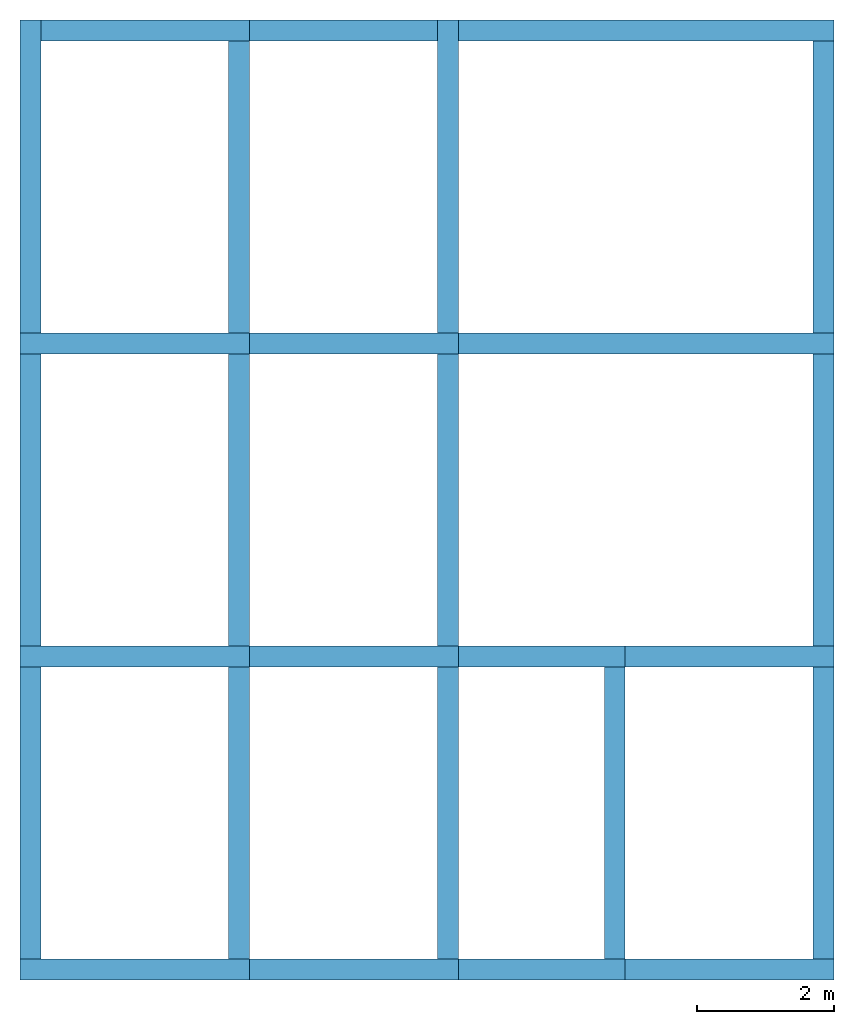
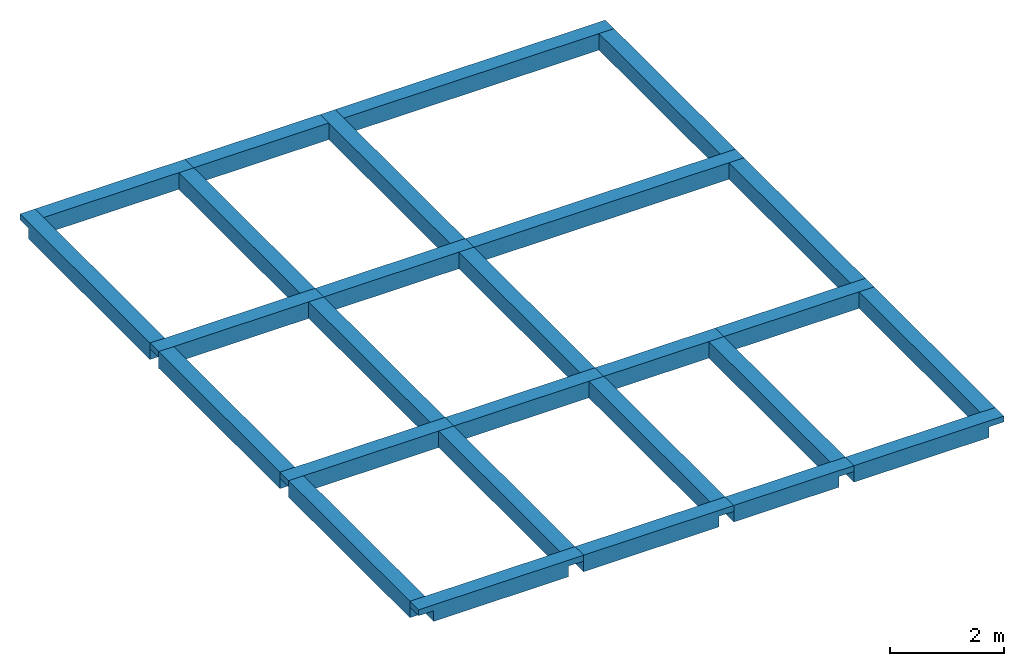
# One storey: 27 beams.
"""IFC2X3 building model written with IfcOpenShell, lengths in feet."""

from ifc_helpers import new_model, entity, si_unit, converted_unit, derived_unit, direction, frame, frame_2d, origin, place, context, subcontext, project, spatial, rectangle, extrude, faceted_brep, material, type_object, element, save


model = new_model("IFC2X3")

# Units and contexts
model_context = context("Model", 3, precision=0.0001, world=origin(), true_north=direction((6.123031769111886e-17, 1.0)))
body_context = subcontext(model_context, "Body", "Model", "MODEL_VIEW")
ifc_project = project(units=[converted_unit("LENGTHUNIT", "FOOT", entity("IfcLengthMeasure", 0.3048), si_unit("LENGTHUNIT", "METRE"), dimensions=[1, 0, 0, 0, 0, 0, 0]), converted_unit("AREAUNIT", "SQUARE FOOT", entity("IfcAreaMeasure", 0.09290304), si_unit("AREAUNIT", "SQUARE_METRE"), dimensions=[2, 0, 0, 0, 0, 0, 0]), converted_unit("VOLUMEUNIT", "CUBIC FOOT", entity("IfcVolumeMeasure", 0.028316846592000004), si_unit("VOLUMEUNIT", "CUBIC_METRE"), dimensions=[3, 0, 0, 0, 0, 0, 0]), converted_unit("PLANEANGLEUNIT", "DEGREE", entity("IfcPlaneAngleMeasure", 0.017453292519943278), si_unit("PLANEANGLEUNIT", "RADIAN"), dimensions=[0, 0, 0, 0, 0, 0, 0]), si_unit("MASSUNIT", "GRAM", prefix="KILO"), derived_unit("MASSDENSITYUNIT", [(si_unit("MASSUNIT", "GRAM", prefix="KILO"), 1), (si_unit("LENGTHUNIT", "METRE"), -3)]), derived_unit("IONCONCENTRATIONUNIT", [(si_unit("MASSUNIT", "GRAM", prefix="KILO"), 1), (si_unit("LENGTHUNIT", "METRE"), -3)]), derived_unit("MOMENTOFINERTIAUNIT", [(si_unit("LENGTHUNIT", "METRE"), 4)]), si_unit("TIMEUNIT", "SECOND"), si_unit("FREQUENCYUNIT", "HERTZ"), si_unit("THERMODYNAMICTEMPERATUREUNIT", "DEGREE_CELSIUS"), derived_unit("THERMALTRANSMITTANCEUNIT", [(si_unit("MASSUNIT", "GRAM", prefix="KILO"), 1), (si_unit("THERMODYNAMICTEMPERATUREUNIT", "KELVIN"), -1), (si_unit("TIMEUNIT", "SECOND"), -3)]), derived_unit("THERMALCONDUCTANCEUNIT", [(si_unit("MASSUNIT", "GRAM", prefix="KILO"), 1), (si_unit("THERMODYNAMICTEMPERATUREUNIT", "KELVIN"), -1), (si_unit("TIMEUNIT", "SECOND"), -3), (si_unit("LENGTHUNIT", "METRE"), 1)]), derived_unit("VOLUMETRICFLOWRATEUNIT", [(si_unit("LENGTHUNIT", "METRE"), 3), (si_unit("TIMEUNIT", "SECOND"), -1)]), derived_unit("MASSFLOWRATEUNIT", [(si_unit("MASSUNIT", "GRAM", prefix="KILO"), 1), (si_unit("TIMEUNIT", "SECOND"), -1)]), derived_unit("ROTATIONALFREQUENCYUNIT", [(si_unit("TIMEUNIT", "SECOND"), -1)]), si_unit("ELECTRICCURRENTUNIT", "AMPERE"), si_unit("ELECTRICVOLTAGEUNIT", "VOLT"), si_unit("POWERUNIT", "WATT"), converted_unit("FORCEUNIT", "KIP", entity("IfcForceMeasure", 2.088543423315013e-05), si_unit("FORCEUNIT", "NEWTON"), dimensions=[1, 1, -2, 0, 0, 0, 0]), si_unit("ILLUMINANCEUNIT", "LUX"), si_unit("LUMINOUSFLUXUNIT", "LUMEN"), si_unit("LUMINOUSINTENSITYUNIT", "CANDELA"), si_unit("ENERGYUNIT", "JOULE"), derived_unit("USERDEFINED", [(si_unit("MASSUNIT", "GRAM", prefix="KILO"), -1), (si_unit("LENGTHUNIT", "METRE"), -2), (si_unit("TIMEUNIT", "SECOND"), 3), (si_unit("LUMINOUSFLUXUNIT", "LUMEN"), 1)]), derived_unit("USERDEFINED", [(si_unit("MASSUNIT", "GRAM", prefix="KILO"), 1), (si_unit("TIMEUNIT", "SECOND"), -3), (si_unit("LENGTHUNIT", "METRE"), 3), (si_unit("ELECTRICCURRENTUNIT", "AMPERE"), -2)]), derived_unit("SOUNDPOWERUNIT", [(si_unit("MASSUNIT", "GRAM", prefix="KILO"), 1), (si_unit("TIMEUNIT", "SECOND"), -3), (si_unit("LENGTHUNIT", "METRE"), 2)]), derived_unit("SOUNDPRESSUREUNIT", [(si_unit("MASSUNIT", "GRAM", prefix="KILO"), 1), (si_unit("LENGTHUNIT", "METRE"), -1), (si_unit("TIMEUNIT", "SECOND"), -2)]), derived_unit("LINEARVELOCITYUNIT", [(si_unit("LENGTHUNIT", "METRE"), 1), (si_unit("TIMEUNIT", "SECOND"), -1)]), si_unit("PRESSUREUNIT", "PASCAL"), derived_unit("USERDEFINED", [(si_unit("MASSUNIT", "GRAM", prefix="KILO"), 1), (si_unit("LENGTHUNIT", "METRE"), -2), (si_unit("TIMEUNIT", "SECOND"), -2)]), derived_unit("LINEARFORCEUNIT", [(si_unit("MASSUNIT", "GRAM", prefix="KILO"), 1), (si_unit("TIMEUNIT", "SECOND"), -2)]), derived_unit("PLANARFORCEUNIT", [(si_unit("MASSUNIT", "GRAM", prefix="KILO"), 1), (si_unit("LENGTHUNIT", "METRE"), -1), (si_unit("TIMEUNIT", "SECOND"), -2)]), derived_unit("SPECIFICHEATCAPACITYUNIT", [(si_unit("THERMODYNAMICTEMPERATUREUNIT", "KELVIN"), -1), (si_unit("LENGTHUNIT", "METRE"), 2), (si_unit("TIMEUNIT", "SECOND"), -2)]), derived_unit("HEATFLUXDENSITYUNIT", [(si_unit("MASSUNIT", "GRAM", prefix="KILO"), 1), (si_unit("TIMEUNIT", "SECOND"), -3)]), derived_unit("HEATINGVALUEUNIT", [(si_unit("LENGTHUNIT", "METRE"), 2), (si_unit("TIMEUNIT", "SECOND"), -2)]), derived_unit("VAPORPERMEABILITYUNIT", [(si_unit("LENGTHUNIT", "METRE"), -1), (si_unit("TIMEUNIT", "SECOND"), 1)]), derived_unit("DYNAMICVISCOSITYUNIT", [(si_unit("MASSUNIT", "GRAM", prefix="KILO"), 1), (si_unit("TIMEUNIT", "SECOND"), -1), (si_unit("LENGTHUNIT", "METRE"), -1)]), derived_unit("THERMALEXPANSIONCOEFFICIENTUNIT", [(si_unit("THERMODYNAMICTEMPERATUREUNIT", "KELVIN"), -1)]), derived_unit("MODULUSOFELASTICITYUNIT", [(si_unit("MASSUNIT", "GRAM", prefix="KILO"), 1), (si_unit("LENGTHUNIT", "METRE"), -1), (si_unit("TIMEUNIT", "SECOND"), -2)]), derived_unit("ISOTHERMALMOISTURECAPACITYUNIT", [(si_unit("LENGTHUNIT", "METRE"), 3), (si_unit("MASSUNIT", "GRAM", prefix="KILO"), -1)]), derived_unit("MOISTUREDIFFUSIVITYUNIT", [(si_unit("TIMEUNIT", "SECOND"), -1), (si_unit("LENGTHUNIT", "METRE"), 2)]), derived_unit("MASSPERLENGTHUNIT", [(si_unit("MASSUNIT", "GRAM", prefix="KILO"), 1), (si_unit("LENGTHUNIT", "METRE"), -1)]), derived_unit("THERMALRESISTANCEUNIT", [(si_unit("MASSUNIT", "GRAM", prefix="KILO"), -1), (si_unit("TIMEUNIT", "SECOND"), 3), (si_unit("THERMODYNAMICTEMPERATUREUNIT", "KELVIN"), 1)]), derived_unit("ACCELERATIONUNIT", [(si_unit("LENGTHUNIT", "METRE"), 1), (si_unit("TIMEUNIT", "SECOND"), -2)]), derived_unit("ANGULARVELOCITYUNIT", [(si_unit("TIMEUNIT", "SECOND"), -1), (si_unit("PLANEANGLEUNIT", "RADIAN"), 1)]), derived_unit("LINEARSTIFFNESSUNIT", [(si_unit("MASSUNIT", "GRAM", prefix="KILO"), 1), (si_unit("TIMEUNIT", "SECOND"), -2)]), derived_unit("WARPINGCONSTANTUNIT", [(si_unit("LENGTHUNIT", "METRE"), 6)]), derived_unit("LINEARMOMENTUNIT", [(si_unit("MASSUNIT", "GRAM", prefix="KILO"), 1), (si_unit("LENGTHUNIT", "METRE"), 1), (si_unit("TIMEUNIT", "SECOND"), -2)]), derived_unit("TORQUEUNIT", [(si_unit("MASSUNIT", "GRAM", prefix="KILO"), 1), (si_unit("LENGTHUNIT", "METRE"), 2), (si_unit("TIMEUNIT", "SECOND"), -2)])], contexts=[model_context])

# Site, building, storey
site_placement = place(None, origin())
site = spatial("IfcSite", under=ifc_project, at=site_placement, CompositionType="ELEMENT")
building_placement = place(site_placement, origin())
building = spatial("IfcBuilding", under=site, at=building_placement, CompositionType="ELEMENT")
storey_placement = place(building_placement, frame((0.0, 0.0, 9.416666666668288)))
storey = spatial("IfcBuildingStorey", under=building, at=storey_placement, Name="First Floor", CompositionType="ELEMENT", Elevation=9.416666666668288)

# Beams
ifc_material = material(Name="Concrete, Cast-in-Place gray")
beam_type = type_object("IfcBeamType", PredefinedType="NOTDEFINED")
beam_1_placement = place(storey_placement, frame((9.374478019163101, -50.34124484724898, -1.1666666666666714)))
element("IfcBeam", 1, at=beam_1_placement, inside=storey, type_object=beam_type, material=ifc_material, context=body_context, shape_type="Brep", body=[
    faceted_brep([(11.0, 0.0, 1.1666666666666643), (11.0, 1.0, 1.1666666666666643), (10.0, 1.0, 1.1666666666666643), (1.0, 1.0, 1.1666666666666643), (0.0, 1.0, 1.1666666666666643), (0.0, 0.0, 1.1666666666666643), (0.0, 0.0, 0.7499999999983835), (1.0, 0.0, 0.7499999999983835), (1.0, 0.0, 0.0), (10.0, 0.0, 0.0), (10.0, 0.0, 0.7499999999983835), (11.0, 0.0, 0.7499999999983835), (1.0, 0.8333333333334352, 0.0), (1.0, 1.0, 0.0), (10.0, 1.0, 0.0), (10.0, 0.8333333333334707, 0.0), (11.0, 1.0, 0.7499999999983835), (10.0, 1.0, 0.7499999999983835), (1.0, 1.0, 0.7499999999983835), (0.0, 1.0, 0.7499999999983835)], [[[0, 1, 2, 3, 4, 5]], [[0, 5, 6, 7, 8, 9, 10, 11]], [[8, 12, 13, 14, 15, 9]], [[4, 3, 2, 1, 16, 17, 14, 13, 18, 19]], [[1, 0, 11, 16]], [[5, 4, 19, 6]], [[7, 18, 13, 12, 8]], [[18, 7, 6, 19]], [[17, 10, 9, 15, 14]], [[10, 17, 16, 11]]]),
])
beam_2_placement = place(storey_placement, frame((20.374478019163305, -50.34124484724902, -1.1666666666666714)))
element("IfcBeam", 2, at=beam_2_placement, inside=storey, type_object=beam_type, material=ifc_material, context=body_context, shape_type="Brep", body=[
    faceted_brep([(10.0, 0.0, 1.1666666666666643), (10.0, 1.0, 1.1666666666666643), (9.0, 1.0, 1.1666666666666643), (0.0, 1.0, 1.1666666666666643), (0.0, 0.0, 1.1666666666666643), (0.0, 0.0, 0.7499999999983835), (0.0, 0.0, 0.0), (9.0, 0.0, 0.0), (9.0, 0.0, 0.7499999999983835), (10.0, 0.0, 0.7499999999983835), (0.0, 0.8333333333334778, 0.0), (0.0, 1.0, 0.0), (9.0, 1.0, 0.0), (9.0, 0.8333333333335062, 0.0), (10.0, 1.0, 0.7499999999983835), (9.0, 1.0, 0.7499999999983835), (0.0, 1.0, 0.7499999999983835)], [[[0, 1, 2, 3, 4]], [[0, 4, 5, 6, 7, 8, 9]], [[6, 10, 11, 12, 13, 7]], [[3, 2, 1, 14, 15, 12, 11, 16]], [[1, 0, 9, 14]], [[4, 3, 16, 11, 10, 6, 5]], [[15, 8, 7, 13, 12]], [[8, 15, 14, 9]]]),
])
beam_3_placement = place(storey_placement, frame((30.374478019163135, -50.34124484724903, -1.1666666666666732)))
element("IfcBeam", 3, at=beam_3_placement, inside=storey, type_object=beam_type, material=ifc_material, context=body_context, shape_type="Brep", body=[
    faceted_brep([(8.0, 0.0, 1.166666666666666), (8.0, 1.0, 1.166666666666666), (7.0, 1.0, 1.166666666666666), (0.0, 1.0, 1.166666666666666), (0.0, 0.0, 1.1666666666666679), (0.0, 0.0, 0.7499999999983853), (0.0, 0.0, 0.0), (7.0, 0.0, 0.0), (7.0, 0.0, 0.7499999999983853), (8.0, 0.0, 0.7499999999983853), (0.0, 0.8333333333334849, 0.0), (0.0, 1.0, 0.0), (7.0, 1.0, 0.0), (7.0, 0.8333333333335062, 0.0), (8.0, 1.0, 0.7499999999983853), (7.0, 1.0, 0.7499999999983853), (0.0, 1.0, 0.7499999999983853)], [[[0, 1, 2, 3, 4]], [[0, 4, 5, 6, 7, 8, 9]], [[6, 10, 11, 12, 13, 7]], [[3, 2, 1, 14, 15, 12, 11, 16]], [[1, 0, 9, 14]], [[4, 3, 16, 11, 10, 6, 5]], [[15, 8, 7, 13, 12]], [[8, 15, 14, 9]]]),
])
beam_4_placement = place(storey_placement, frame((38.37447801916311, -50.34124484724908, -1.1666666666666714)))
element("IfcBeam", 4, at=beam_4_placement, inside=storey, type_object=beam_type, material=ifc_material, context=body_context, shape_type="Brep", body=[
    faceted_brep([(10.0, 0.0, 1.1666666666666643), (10.0, 1.0, 1.1666666666666643), (9.0, 1.0, 1.1666666666666643), (0.0, 1.0, 1.1666666666666643), (0.0, 0.0, 1.1666666666666643), (0.0, 0.0, 0.7499999999983835), (0.0, 0.0, 0.0), (9.0, 0.0, 0.0), (9.0, 0.0, 0.7499999999983835), (10.0, 0.0, 0.7499999999983835), (0.0, 0.8333333333335347, 0.0), (0.0, 1.0, 0.0), (9.0, 1.0, 0.0), (9.0, 0.8333333333335631, 0.0), (10.0, 1.0, 0.7499999999983835), (9.0, 1.0, 0.7499999999983835), (0.0, 1.0, 0.7499999999983835)], [[[0, 1, 2, 3, 4]], [[0, 4, 5, 6, 7, 8, 9]], [[6, 10, 11, 12, 13, 7]], [[3, 2, 1, 14, 15, 12, 11, 16]], [[1, 0, 9, 14]], [[4, 3, 16, 11, 10, 6, 5]], [[15, 8, 7, 13, 12]], [[8, 15, 14, 9]]]),
])
beam_5_placement = place(storey_placement, frame((9.374478019163123, -35.34124484724898, -1.1666666666666714)))
element("IfcBeam", 5, at=beam_5_placement, inside=storey, type_object=beam_type, material=ifc_material, context=body_context, shape_type="Brep", body=[
    faceted_brep([(11.0, 0.0, 1.1666666666666643), (11.0, 1.0, 1.1666666666666643), (10.0, 1.0, 1.1666666666666643), (1.0, 1.0, 1.1666666666666643), (0.0, 1.0, 1.1666666666666643), (0.0, 0.0, 1.1666666666666643), (1.0, 0.0, 1.1666666666666643), (10.0, 0.0, 1.1666666666666643), (0.0, 0.0, 0.7499999999983835), (1.0, 0.0, 0.7499999999983835), (1.0, 0.0, 0.0), (10.0, 0.0, 0.0), (10.0, 0.0, 0.7499999999983835), (11.0, 0.0, 0.7499999999983835), (1.0, 1.0, 0.0), (10.0, 1.0, 0.0), (11.0, 1.0, 0.7499999999983835), (10.0, 1.0, 0.7499999999983835), (1.0, 1.0, 0.7499999999983835), (0.0, 1.0, 0.7499999999983835)], [[[0, 1, 2, 3, 4, 5, 6, 7]], [[0, 7, 6, 5, 8, 9, 10, 11, 12, 13]], [[10, 14, 15, 11]], [[4, 3, 2, 1, 16, 17, 15, 14, 18, 19]], [[1, 0, 13, 16]], [[5, 4, 19, 8]], [[9, 18, 14, 10]], [[18, 9, 8, 19]], [[17, 12, 11, 15]], [[12, 17, 16, 13]]]),
])
beam_6_placement = place(storey_placement, frame((20.374478019163327, -35.34124484724902, -1.1666666666666714)))
element("IfcBeam", 6, at=beam_6_placement, inside=storey, type_object=beam_type, material=ifc_material, context=body_context, shape_type="Brep", body=[
    faceted_brep([(10.0, 0.0, 1.1666666666666643), (10.0, 1.0, 1.1666666666666643), (9.0, 1.0, 1.1666666666666643), (0.0, 1.0, 1.1666666666666643), (0.0, 0.0, 1.1666666666666643), (9.0, 0.0, 1.1666666666666643), (0.0, 0.0, 0.7499999999983835), (0.0, 0.0, 0.0), (9.0, 0.0, 0.0), (9.0, 0.0, 0.7499999999983835), (10.0, 0.0, 0.7499999999983835), (0.0, 1.0, 0.0), (9.0, 1.0, 0.0), (10.0, 1.0, 0.7499999999983835), (9.0, 1.0, 0.7499999999983835), (0.0, 1.0, 0.7499999999983835)], [[[0, 1, 2, 3, 4, 5]], [[0, 5, 4, 6, 7, 8, 9, 10]], [[7, 11, 12, 8]], [[3, 2, 1, 13, 14, 12, 11, 15]], [[1, 0, 10, 13]], [[4, 3, 15, 11, 7, 6]], [[14, 9, 8, 12]], [[9, 14, 13, 10]]]),
])
beam_7_placement = place(storey_placement, frame((30.37447801916315, -35.34124484724903, -1.1666666666666732)))
element("IfcBeam", 7, at=beam_7_placement, inside=storey, type_object=beam_type, material=ifc_material, context=body_context, shape_type="Brep", body=[
    faceted_brep([(8.0, 0.0, 1.166666666666666), (8.0, 1.0, 1.166666666666666), (0.0, 1.0, 1.166666666666666), (0.0, 0.0, 1.1666666666666679), (7.0, 0.0, 1.1666666666666679), (0.0, 0.0, 0.7499999999983853), (0.0, 0.0, 0.0), (7.0, 0.0, 0.0), (7.0, 0.0, 0.7499999999983853), (8.0, 0.0, 0.7499999999983853), (0.0, 1.0, 0.0), (7.0, 1.0, 0.0), (8.0, 1.0, 0.7499999999983853), (7.0, 1.0, 0.7499999999983853), (0.0, 1.0, 0.7499999999983853)], [[[0, 1, 2, 3, 4]], [[0, 4, 3, 5, 6, 7, 8, 9]], [[6, 10, 11, 7]], [[2, 1, 12, 13, 11, 10, 14]], [[1, 0, 9, 12]], [[3, 2, 14, 10, 6, 5]], [[13, 8, 7, 11]], [[8, 13, 12, 9]]]),
])
beam_8_placement = place(storey_placement, frame((38.37447801916313, -35.34124484724908, -1.1666666666666714)))
element("IfcBeam", 8, at=beam_8_placement, inside=storey, type_object=beam_type, material=ifc_material, context=body_context, shape_type="Brep", body=[
    faceted_brep([(10.0, 0.0, 1.1666666666666643), (10.0, 1.0, 1.1666666666666643), (9.0, 1.0, 1.1666666666666643), (0.0, 1.0, 1.1666666666666643), (0.0, 0.0, 1.1666666666666643), (9.0, 0.0, 1.1666666666666643), (0.0, 0.0, 0.7499999999983835), (0.0, 0.0, 0.0), (9.0, 0.0, 0.0), (9.0, 0.0, 0.7499999999983835), (10.0, 0.0, 0.7499999999983835), (0.0, 1.0, 0.0), (9.0, 1.0, 0.0), (10.0, 1.0, 0.7499999999983835), (9.0, 1.0, 0.7499999999983835), (0.0, 1.0, 0.7499999999983835)], [[[0, 1, 2, 3, 4, 5]], [[0, 5, 4, 6, 7, 8, 9, 10]], [[7, 11, 12, 8]], [[3, 2, 1, 13, 14, 12, 11, 15]], [[1, 0, 10, 13]], [[4, 3, 15, 11, 7, 6]], [[14, 9, 8, 12]], [[9, 14, 13, 10]]]),
])
beam_9_placement = place(storey_placement, frame((9.374478019163147, -20.341244847248984, -1.1666666666666714)))
element("IfcBeam", 9, at=beam_9_placement, inside=storey, type_object=beam_type, material=ifc_material, context=body_context, shape_type="Brep", body=[
    faceted_brep([(11.0, 0.0, 1.1666666666666643), (11.0, 1.0, 1.1666666666666643), (10.0, 1.0, 1.1666666666666643), (1.0, 1.0, 1.1666666666666643), (0.0, 1.0, 1.1666666666666643), (0.0, 0.0, 1.1666666666666643), (1.0, 0.0, 1.1666666666666643), (10.0, 0.0, 1.1666666666666643), (0.0, 0.0, 0.7499999999983835), (1.0, 0.0, 0.7499999999983835), (1.0, 0.0, 0.0), (10.0, 0.0, 0.0), (10.0, 0.0, 0.7499999999983835), (11.0, 0.0, 0.7499999999983835), (1.0, 1.0, 0.0), (10.0, 1.0, 0.0), (11.0, 1.0, 0.7499999999983835), (10.0, 1.0, 0.7499999999983835), (1.0, 1.0, 0.7499999999983835), (0.0, 1.0, 0.7499999999983835)], [[[0, 1, 2, 3, 4, 5, 6, 7]], [[0, 7, 6, 5, 8, 9, 10, 11, 12, 13]], [[10, 14, 15, 11]], [[4, 3, 2, 1, 16, 17, 15, 14, 18, 19]], [[1, 0, 13, 16]], [[5, 4, 19, 8]], [[9, 18, 14, 10]], [[18, 9, 8, 19]], [[17, 12, 11, 15]], [[12, 17, 16, 13]]]),
])
beam_10_placement = place(storey_placement, frame((20.374478019163355, -20.341244847249012, -1.1666666666666714)))
element("IfcBeam", 10, at=beam_10_placement, inside=storey, type_object=beam_type, material=ifc_material, context=body_context, shape_type="Brep", body=[
    faceted_brep([(10.0, 0.0, 1.1666666666666643), (10.0, 1.0, 1.1666666666666643), (9.0, 1.0, 1.1666666666666643), (0.0, 1.0, 1.1666666666666643), (0.0, 0.0, 1.1666666666666643), (9.0, 0.0, 1.1666666666666643), (0.0, 0.0, 0.7499999999983835), (0.0, 0.0, 0.0), (9.0, 0.0, 0.0), (9.0, 0.0, 0.7499999999983835), (10.0, 0.0, 0.7499999999983835), (0.0, 1.0, 0.0), (9.0, 1.0, 0.0), (10.0, 1.0, 0.7499999999983835), (9.0, 1.0, 0.7499999999983835), (0.0, 1.0, 0.7499999999983835)], [[[0, 1, 2, 3, 4, 5]], [[0, 5, 4, 6, 7, 8, 9, 10]], [[7, 11, 12, 8]], [[3, 2, 1, 13, 14, 12, 11, 15]], [[1, 0, 10, 13]], [[4, 3, 15, 11, 7, 6]], [[14, 9, 8, 12]], [[9, 14, 13, 10]]]),
])
beam_11_placement = place(storey_placement, frame((30.374478019163178, -20.341244847249072, -1.1666666666666732)))
element("IfcBeam", 11, at=beam_11_placement, inside=storey, type_object=beam_type, material=ifc_material, context=body_context, shape_type="Brep", body=[
    faceted_brep([(18.0, 0.0, 1.166666666666666), (18.0, 1.0, 1.166666666666666), (17.0, 1.0, 1.166666666666666), (0.0, 1.0, 1.166666666666666), (0.0, 0.0, 1.1666666666666679), (17.0, 0.0, 1.1666666666666679), (0.0, 0.0, 0.7499999999983853), (0.0, 0.0, 0.0), (17.0, 0.0, 0.0), (17.0, 0.0, 0.7499999999983853), (18.0, 0.0, 0.7499999999983853), (0.0, 1.0, 0.0), (17.0, 1.0, 0.0), (18.0, 1.0, 0.7499999999983853), (17.0, 1.0, 0.7499999999983853), (0.0, 1.0, 0.7499999999983853)], [[[0, 1, 2, 3, 4, 5]], [[0, 5, 4, 6, 7, 8, 9, 10]], [[7, 11, 12, 8]], [[3, 2, 1, 13, 14, 12, 11, 15]], [[1, 0, 10, 13]], [[4, 3, 15, 11, 7, 6]], [[14, 9, 8, 12]], [[9, 14, 13, 10]]]),
])
beam_12_placement = place(storey_placement, frame((9.374478019162256, -19.34124484724894, -1.1666666666666732), z_axis=(0.0, 0.0, 1.0), x_axis=(0.0, -1.0, 0.0)))
element("IfcBeam", 12, at=beam_12_placement, inside=storey, type_object=beam_type, material=ifc_material, context=body_context, shape_type="Brep", body=[
    faceted_brep([(-15.0, 1.0, 1.166666666666666), (-15.0, 0.0, 1.1666666666666679), (0.0, 0.0, 1.166666666666666), (0.0, 1.0, 1.166666666666666), (-14.0, 1.0, 1.166666666666666), (-15.0, 0.0, 0.7499999999983853), (-14.0, 0.0, 0.7499999999983853), (-14.0, 0.0, 0.0), (0.0, 0.0, 0.0), (0.0, 0.0, 0.7499999999983853), (0.0, 1.0, 0.0), (0.0, 0.8333333333333366, 0.0), (-14.0, 0.8333333333333134, 0.0), (-14.0, 1.0, 0.0), (0.0, 1.0, 0.7499999999983853), (-14.0, 1.0, 0.7499999999983853), (-15.0, 1.0, 0.7499999999983853)], [[[0, 1, 2, 3, 4]], [[2, 1, 5, 6, 7, 8, 9]], [[10, 11, 8, 7, 12, 13]], [[0, 4, 3, 14, 10, 13, 15, 16]], [[1, 0, 16, 5]], [[3, 2, 9, 8, 11, 10, 14]], [[6, 15, 13, 12, 7]], [[15, 6, 5, 16]]]),
])
beam_13_placement = place(storey_placement, frame((9.874478019163162, -19.841244847248934, 0.0), z_axis=(0.0, 0.0, 1.0), x_axis=(0.0, -1.0, 0.0)))
element("IfcBeam", 13, at=beam_13_placement, inside=storey, type_object=beam_type, material=ifc_material, context=body_context, shape_type="SweptSolid", body=[
    extrude(rectangle(XDim=1.166666666666666, YDim=1.0000000000000107, at=frame_2d((8.881784197001252e-16, -1.7763568394002505e-15), x_axis=(1.0, 0.0))), frame((0.5000000000000142, 0.0, -0.5833333333333393), z_axis=(1.0, 0.0, 0.0), x_axis=(0.0, 0.0, -1.0)), (0.0, 0.0, 1.0), 13.999999999999995),
])
beam_14_placement = place(storey_placement, frame((9.874478019163138, -34.84124484724893, 0.0), z_axis=(0.0, 0.0, 1.0), x_axis=(0.0, -1.0, 0.0)))
element("IfcBeam", 14, at=beam_14_placement, inside=storey, type_object=beam_type, material=ifc_material, context=body_context, shape_type="SweptSolid", body=[
    extrude(rectangle(XDim=1.166666666666666, YDim=1.0000000000000107, at=frame_2d((8.881784197001252e-16, -1.7763568394002505e-15), x_axis=(1.0, 0.0))), frame((0.5000000000000071, 0.0, -0.5833333333333393), z_axis=(1.0, 0.0, 0.0), x_axis=(0.0, 0.0, -1.0)), (0.0, 0.0, 1.0), 14.000000000000005),
])
beam_15_placement = place(storey_placement, frame((29.374478019162254, -19.341244847249, -1.1666666666666732), z_axis=(0.0, 0.0, 1.0), x_axis=(0.0, -1.0, 0.0)))
element("IfcBeam", 15, at=beam_15_placement, inside=storey, type_object=beam_type, material=ifc_material, context=body_context, shape_type="Brep", body=[
    faceted_brep([(-15.0, 1.0, 1.166666666666666), (-15.0, 0.0, 1.1666666666666679), (-14.0, 0.0, 1.1666666666666679), (0.0, 0.0, 1.166666666666666), (0.0, 1.0, 1.166666666666666), (-14.0, 1.0, 1.166666666666666), (-15.0, 0.0, 0.7499999999983853), (-14.0, 0.0, 0.7499999999983853), (-14.0, 0.0, 0.0), (0.0, 0.0, 0.0), (0.0, 0.0, 0.7499999999983853), (0.0, 1.0, 0.0), (-14.0, 1.0, 0.0), (0.0, 1.0, 0.7499999999983853), (-14.0, 1.0, 0.7499999999983853), (-15.0, 1.0, 0.7499999999983853)], [[[0, 1, 2, 3, 4, 5]], [[3, 2, 1, 6, 7, 8, 9, 10]], [[11, 9, 8, 12]], [[0, 5, 4, 13, 11, 12, 14, 15]], [[1, 0, 15, 6]], [[4, 3, 10, 9, 11, 13]], [[7, 14, 12, 8]], [[14, 7, 6, 15]]]),
])
beam_16_placement = place(storey_placement, frame((29.874478019163178, -19.841244847248998, 0.0), z_axis=(0.0, 0.0, 1.0), x_axis=(0.0, -1.0, 0.0)))
element("IfcBeam", 16, at=beam_16_placement, inside=storey, type_object=beam_type, material=ifc_material, context=body_context, shape_type="SweptSolid", body=[
    extrude(rectangle(XDim=1.166666666666666, YDim=1.0000000000000142, at=frame_2d((8.881784197001252e-16, -3.552713678800501e-15), x_axis=(1.0, 0.0))), frame((0.5000000000000107, 0.0, -0.5833333333333393), z_axis=(1.0, 0.0, 0.0), x_axis=(0.0, 0.0, -1.0)), (0.0, 0.0, 1.0), 14.0),
])
beam_17_placement = place(storey_placement, frame((29.874478019163153, -34.841244847249, 0.0), z_axis=(0.0, 0.0, 1.0), x_axis=(0.0, -1.0, 0.0)))
element("IfcBeam", 17, at=beam_17_placement, inside=storey, type_object=beam_type, material=ifc_material, context=body_context, shape_type="SweptSolid", body=[
    extrude(rectangle(XDim=1.166666666666666, YDim=1.0000000000000142, at=frame_2d((8.881784197001252e-16, -3.552713678800501e-15), x_axis=(1.0, 0.0))), frame((0.5000000000000142, 0.0, -0.5833333333333393), z_axis=(1.0, 0.0, 0.0), x_axis=(0.0, 0.0, -1.0)), (0.0, 0.0, 1.0), 13.999999999999993),
])
beam_18_placement = place(storey_placement, frame((37.87447801916313, -34.84124484724902, 0.0), z_axis=(0.0, 0.0, 1.0), x_axis=(0.0, -1.0, 0.0)))
element("IfcBeam", 18, at=beam_18_placement, inside=storey, type_object=beam_type, material=ifc_material, context=body_context, shape_type="SweptSolid", body=[
    extrude(rectangle(XDim=1.166666666666666, YDim=1.0000000000000142, at=frame_2d((8.881784197001252e-16, 0.0), x_axis=(1.0, 0.0))), frame((0.5000000000000142, 0.0, -0.5833333333333393), z_axis=(1.0, 0.0, 0.0), x_axis=(0.0, 0.0, -1.0)), (0.0, 0.0, 1.0), 13.999999999999993),
])
beam_19_placement = place(storey_placement, frame((10.374478019163183, -5.341244847248929, -1.1666666666666714)))
element("IfcBeam", 19, at=beam_19_placement, inside=storey, type_object=beam_type, material=ifc_material, context=body_context, shape_type="Brep", body=[
    faceted_brep([(10.0, 0.0, 1.1666666666666643), (10.0, 1.0, 1.1666666666666643), (0.0, 1.0, 1.1666666666666643), (0.0, 0.0, 1.1666666666666643), (9.0, 0.0, 1.1666666666666643), (0.0, 0.0, 0.7499999999983835), (0.0, 0.0, 0.0), (9.0, 0.0, 0.0), (9.0, 0.0, 0.7499999999983835), (10.0, 0.0, 0.7499999999983835), (0.0, 1.0, 0.0), (9.0, 1.0, 0.0), (10.0, 1.0, 0.7499999999983835), (9.0, 1.0, 0.7499999999983835), (0.0, 1.0, 0.7499999999983835)], [[[0, 1, 2, 3, 4]], [[0, 4, 3, 5, 6, 7, 8, 9]], [[6, 10, 11, 7]], [[2, 1, 12, 13, 11, 10, 14]], [[1, 0, 9, 12]], [[3, 2, 14, 10, 6, 5]], [[13, 8, 7, 11]], [[8, 13, 12, 9]]]),
])
beam_20_placement = place(storey_placement, frame((19.87447801916223, -4.841244847248915, 0.0)))
element("IfcBeam", 20, at=beam_20_placement, inside=storey, type_object=beam_type, material=ifc_material, context=body_context, shape_type="SweptSolid", body=[
    extrude(rectangle(XDim=1.166666666666666, YDim=1.0000000000000115, at=frame_2d((8.881784197001252e-16, -4.440892098500626e-16), x_axis=(1.0, 0.0))), frame((0.5000000000011487, 0.0, -0.5833333333333393), z_axis=(1.0, 0.0, 0.0), x_axis=(0.0, 0.0, -1.0)), (0.0, 0.0, 1.0), 8.999999999999835),
])
beam_21_placement = place(storey_placement, frame((30.374478019163202, -5.341244847249021, -1.1666666666666732)))
element("IfcBeam", 21, at=beam_21_placement, inside=storey, type_object=beam_type, material=ifc_material, context=body_context, shape_type="Brep", body=[
    faceted_brep([(18.0, 0.0, 1.166666666666666), (18.0, 1.0, 1.166666666666666), (0.0, 1.0, 1.166666666666666), (0.0, 0.0, 1.1666666666666679), (17.0, 0.0, 1.1666666666666679), (0.0, 0.0, 0.7499999999983853), (0.0, 0.0, 0.0), (17.0, 0.0, 0.0), (17.0, 0.0, 0.7499999999983853), (18.0, 0.0, 0.7499999999983853), (0.0, 0.1666666666668064, 0.0), (0.0, 1.0, 0.0), (17.0, 1.0, 0.0), (17.0, 0.16666666666686147, 0.0), (18.0, 1.0, 0.7499999999983853), (17.0, 1.0, 0.7499999999983853), (0.0, 1.0, 0.7499999999983853)], [[[0, 1, 2, 3, 4]], [[0, 4, 3, 5, 6, 7, 8, 9]], [[6, 10, 11, 12, 13, 7]], [[2, 1, 14, 15, 12, 11, 16]], [[1, 0, 9, 14]], [[3, 2, 16, 11, 10, 6, 5]], [[15, 8, 7, 13, 12]], [[8, 15, 14, 9]]]),
])
beam_22_placement = place(storey_placement, frame((47.8744780191634, -4.841244847249006, 0.0), z_axis=(0.0, 0.0, 1.0), x_axis=(0.0, -1.0, 0.0)))
element("IfcBeam", 22, at=beam_22_placement, inside=storey, type_object=beam_type, material=ifc_material, context=body_context, shape_type="SweptSolid", body=[
    extrude(rectangle(XDim=1.166666666666666, YDim=1.0000000000000142, at=frame_2d((8.881784197001252e-16, 0.0), x_axis=(1.0, 0.0))), frame((0.5000000000000124, 0.0, -0.5833333333333393), z_axis=(1.0, 0.0, 0.0), x_axis=(0.0, 0.0, -1.0)), (0.0, 0.0, 1.0), 14.000000000000044),
])
beam_23_placement = place(storey_placement, frame((47.87447801916338, -19.841244847249058, 0.0), z_axis=(0.0, 0.0, 1.0), x_axis=(0.0, -1.0, 0.0)))
element("IfcBeam", 23, at=beam_23_placement, inside=storey, type_object=beam_type, material=ifc_material, context=body_context, shape_type="SweptSolid", body=[
    extrude(rectangle(XDim=1.166666666666666, YDim=1.0000000000000142, at=frame_2d((8.881784197001252e-16, 0.0), x_axis=(1.0, 0.0))), frame((0.5000000000000107, 0.0, -0.5833333333333393), z_axis=(1.0, 0.0, 0.0), x_axis=(0.0, 0.0, -1.0)), (0.0, 0.0, 1.0), 13.999999999999995),
])
beam_24_placement = place(storey_placement, frame((47.874478019163355, -34.84124484724906, 0.0), z_axis=(0.0, 0.0, 1.0), x_axis=(0.0, -1.0, 0.0)))
element("IfcBeam", 24, at=beam_24_placement, inside=storey, type_object=beam_type, material=ifc_material, context=body_context, shape_type="SweptSolid", body=[
    extrude(rectangle(XDim=1.166666666666666, YDim=1.0000000000000142, at=frame_2d((8.881784197001252e-16, 0.0), x_axis=(1.0, 0.0))), frame((0.5000000000000142, 0.0, -0.5833333333333393), z_axis=(1.0, 0.0, 0.0), x_axis=(0.0, 0.0, -1.0)), (0.0, 0.0, 1.0), 13.999999999999993),
])
beam_25_placement = place(storey_placement, frame((19.87447801916338, -4.841244847248915, 0.0), z_axis=(0.0, 0.0, 1.0), x_axis=(0.0, -1.0, 0.0)))
element("IfcBeam", 25, at=beam_25_placement, inside=storey, type_object=beam_type, material=ifc_material, context=body_context, shape_type="SweptSolid", body=[
    extrude(rectangle(XDim=1.166666666666666, YDim=1.0000000000000142, at=frame_2d((8.881784197001252e-16, -3.552713678800501e-15), x_axis=(1.0, 0.0))), frame((0.5000000000000107, 0.0, -0.5833333333333393), z_axis=(1.0, 0.0, 0.0), x_axis=(0.0, 0.0, -1.0)), (0.0, 0.0, 1.0), 14.000000000000046),
])
beam_26_placement = place(storey_placement, frame((19.874478019163355, -19.841244847248966, 0.0), z_axis=(0.0, 0.0, 1.0), x_axis=(0.0, -1.0, 0.0)))
element("IfcBeam", 26, at=beam_26_placement, inside=storey, type_object=beam_type, material=ifc_material, context=body_context, shape_type="SweptSolid", body=[
    extrude(rectangle(XDim=1.166666666666666, YDim=1.0000000000000142, at=frame_2d((8.881784197001252e-16, -3.552713678800501e-15), x_axis=(1.0, 0.0))), frame((0.5000000000000142, 0.0, -0.5833333333333393), z_axis=(1.0, 0.0, 0.0), x_axis=(0.0, 0.0, -1.0)), (0.0, 0.0, 1.0), 13.999999999999984),
])
beam_27_placement = place(storey_placement, frame((19.87447801916333, -34.84124484724897, 0.0), z_axis=(0.0, 0.0, 1.0), x_axis=(0.0, -1.0, 0.0)))
element("IfcBeam", 27, at=beam_27_placement, inside=storey, type_object=beam_type, material=ifc_material, context=body_context, shape_type="SweptSolid", body=[
    extrude(rectangle(XDim=1.166666666666666, YDim=1.0000000000000107, at=frame_2d((8.881784197001252e-16, -1.7763568394002505e-15), x_axis=(1.0, 0.0))), frame((0.5, 0.0, -0.5833333333333393), z_axis=(1.0, 0.0, 0.0), x_axis=(0.0, 0.0, -1.0)), (0.0, 0.0, 1.0), 13.999999999999993),
])

save(model, "model.ifc")
